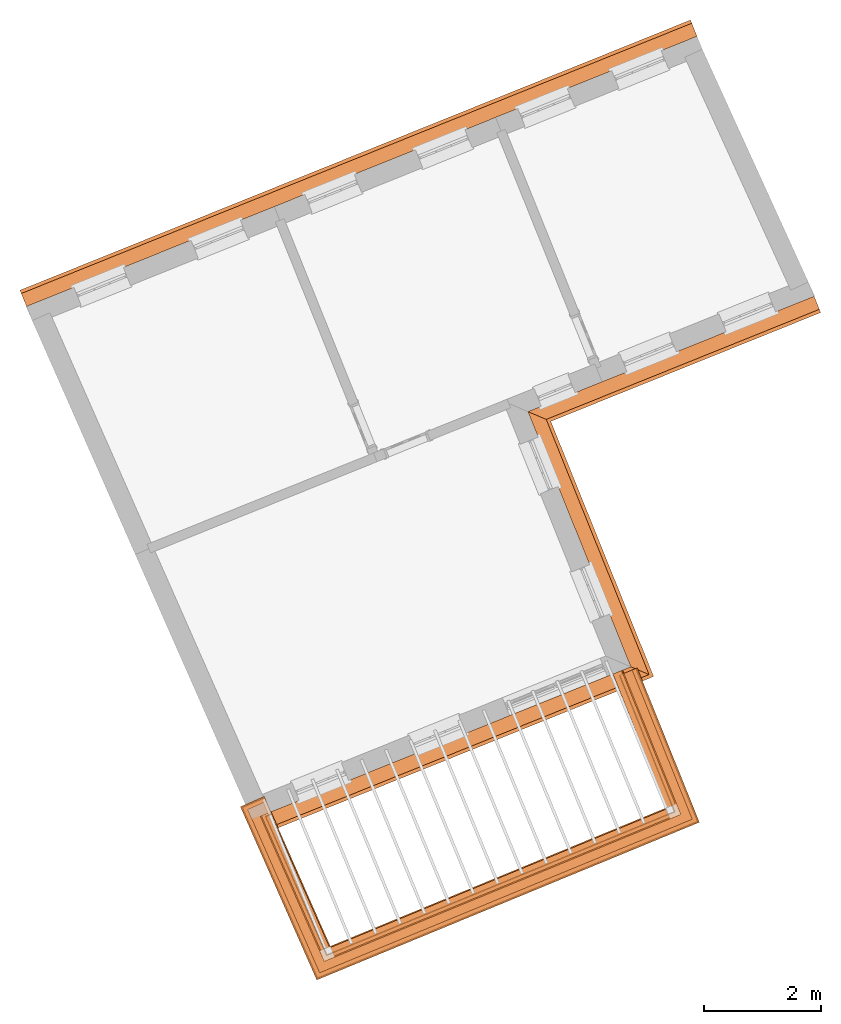
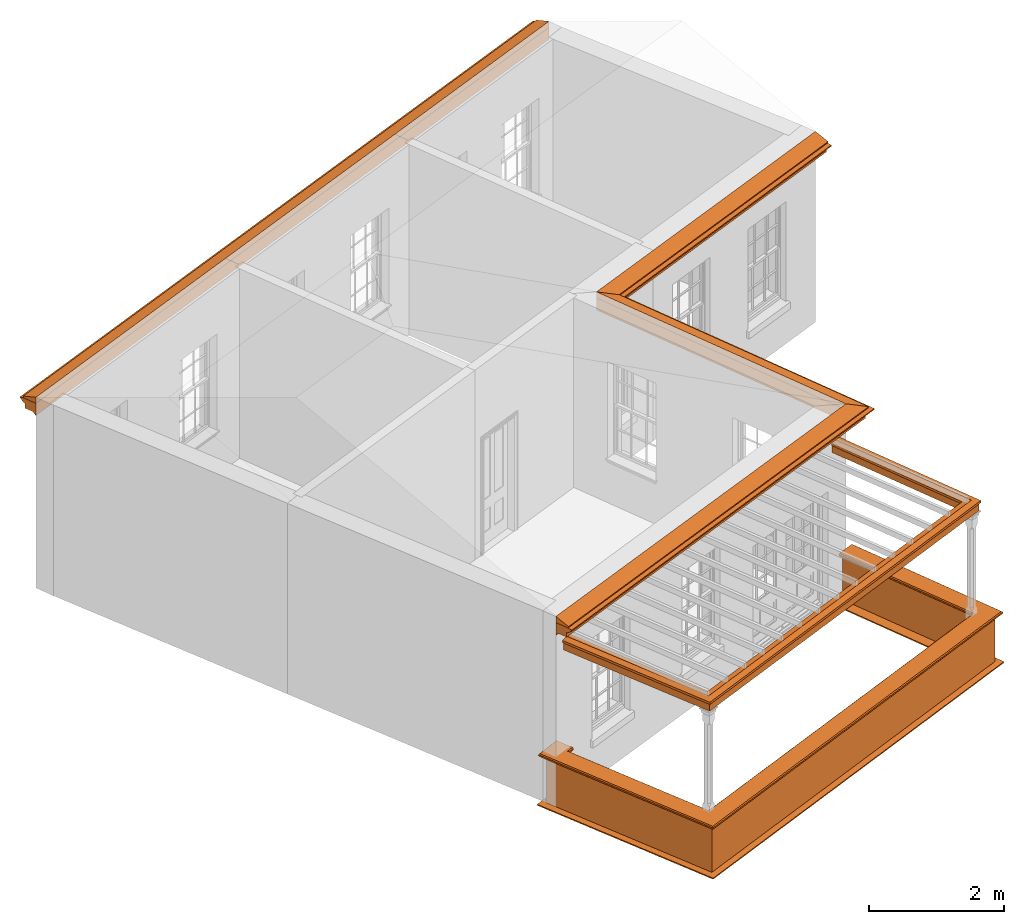
# One storey, part 10 of 11: 9 proxies.
"""IFC2X3 building model written with IfcOpenShell, lengths in metres."""

from ifc_helpers import new_model, entity, si_unit, frame, origin, place, context, subcontext, project, spatial, element, save


model = new_model("IFC2X3")

# Units and contexts
model_context = context("Model", 3, world=origin())
body_context = subcontext(model_context, "Body", "Model", "MODEL_VIEW")
ifc_project = project(units=[si_unit("PLANEANGLEUNIT", "RADIAN"), si_unit("MASSUNIT", "GRAM", prefix="KILO"), si_unit("FORCEUNIT", "NEWTON", prefix="KILO"), si_unit("LENGTHUNIT", "METRE")], contexts=[model_context])

# Site, building, storey
site_placement = place(None, origin())
site = spatial("IfcSite", under=ifc_project, at=site_placement, CompositionType="ELEMENT")
building_placement = place(None, origin())
building = spatial("IfcBuilding", under=site, at=building_placement, Name="Building plot-6", CompositionType="ELEMENT")
storey_placement = place(None, frame((0.0, 0.0, 7.6)))
storey = spatial("IfcBuildingStorey", under=building, at=storey_placement, Name="Floor 1", CompositionType="ELEMENT", Elevation=7.6)

# Proxies
proxy_1_placement = place(storey_placement, frame((0.0, 0.0, 3.45)))
axis2_placement3_d_1 = entity("IfcAxis2Placement3D", entity("IfcCartesianPoint", [0.0, 0.0, 0.0]))
element("IfcBuildingElementProxy", 1, at=proxy_1_placement, inside=storey, Name="eaves", CompositionType="ELEMENT", context=body_context, shape_type="SweptSolid", held_by="IfcProductRepresentation", body=[
    entity("IfcSurfaceCurveSweptAreaSolid", entity("IfcArbitraryClosedProfileDef", "AREA", None, entity("IfcPolyline", [entity("IfcCartesianPoint", [-0.11, 0.25]), entity("IfcCartesianPoint", [-0.33, 0.25]), entity("IfcCartesianPoint", [-0.33, 0.265]), entity("IfcCartesianPoint", [-0.318, 0.268]), entity("IfcCartesianPoint", [-0.309, 0.274]), entity("IfcCartesianPoint", [-0.303, 0.283]), entity("IfcCartesianPoint", [-0.3, 0.295]), entity("IfcCartesianPoint", [-0.285, 0.295]), entity("IfcCartesianPoint", [-0.285, 0.455]), entity("IfcCartesianPoint", [-0.205, 0.455]), entity("IfcCartesianPoint", [-0.205, 0.47]), entity("IfcCartesianPoint", [-0.19, 0.47]), entity("IfcCartesianPoint", [-0.189, 0.483]), entity("IfcCartesianPoint", [-0.186, 0.494]), entity("IfcCartesianPoint", [-0.179, 0.506]), entity("IfcCartesianPoint", [-0.17, 0.514]), entity("IfcCartesianPoint", [-0.16, 0.52]), entity("IfcCartesianPoint", [-0.149, 0.529]), entity("IfcCartesianPoint", [-0.143, 0.539]), entity("IfcCartesianPoint", [-0.14, 0.55]), entity("IfcCartesianPoint", [-0.12, 0.55]), entity("IfcCartesianPoint", [-0.11, 0.48]), entity("IfcCartesianPoint", [-0.11, 0.25])])), axis2_placement3_d_1, entity("IfcPolyline", [entity("IfcCartesianPoint", [74.7865149407705, 68.6935179498722]), entity("IfcCartesianPoint", [63.3420321652464, 64.0810953782074])]), 0.0, 1.0, entity("IfcPlane", axis2_placement3_d_1)),
])
proxy_2_placement = place(storey_placement, frame((0.0, 0.0, 3.45)))
axis2_placement3_d_2 = entity("IfcAxis2Placement3D", entity("IfcCartesianPoint", [0.0, 0.0, 0.0]))
element("IfcBuildingElementProxy", 2, at=proxy_2_placement, inside=storey, Name="eaves", CompositionType="ELEMENT", context=body_context, shape_type="SweptSolid", held_by="IfcProductRepresentation", body=[
    entity("IfcSurfaceCurveSweptAreaSolid", entity("IfcArbitraryClosedProfileDef", "AREA", None, entity("IfcPolyline", [entity("IfcCartesianPoint", [-0.11, 0.25]), entity("IfcCartesianPoint", [-0.11, 0.48]), entity("IfcCartesianPoint", [-0.08, 0.49]), entity("IfcCartesianPoint", [0.0, 0.25]), entity("IfcCartesianPoint", [-0.11, 0.25])])), axis2_placement3_d_2, entity("IfcPolyline", [entity("IfcCartesianPoint", [74.7865149407705, 68.6935179498722]), entity("IfcCartesianPoint", [63.3420321652464, 64.0810953782074])]), 0.0, 1.0, entity("IfcPlane", axis2_placement3_d_2)),
])
proxy_3_placement = place(storey_placement, frame((0.0, 0.0, 3.45)))
axis2_placement3_d_3 = entity("IfcAxis2Placement3D", entity("IfcCartesianPoint", [0.0, 0.0, 0.0]))
element("IfcBuildingElementProxy", 3, at=proxy_3_placement, inside=storey, Name="eaves", CompositionType="ELEMENT", context=body_context, shape_type="SweptSolid", held_by="IfcProductRepresentation", body=[
    entity("IfcSurfaceCurveSweptAreaSolid", entity("IfcArbitraryClosedProfileDef", "AREA", None, entity("IfcPolyline", [entity("IfcCartesianPoint", [-0.11, 0.25]), entity("IfcCartesianPoint", [-0.33, 0.25]), entity("IfcCartesianPoint", [-0.33, 0.265]), entity("IfcCartesianPoint", [-0.318, 0.268]), entity("IfcCartesianPoint", [-0.309, 0.274]), entity("IfcCartesianPoint", [-0.303, 0.283]), entity("IfcCartesianPoint", [-0.3, 0.295]), entity("IfcCartesianPoint", [-0.285, 0.295]), entity("IfcCartesianPoint", [-0.285, 0.455]), entity("IfcCartesianPoint", [-0.205, 0.455]), entity("IfcCartesianPoint", [-0.205, 0.47]), entity("IfcCartesianPoint", [-0.19, 0.47]), entity("IfcCartesianPoint", [-0.189, 0.483]), entity("IfcCartesianPoint", [-0.186, 0.494]), entity("IfcCartesianPoint", [-0.179, 0.506]), entity("IfcCartesianPoint", [-0.17, 0.514]), entity("IfcCartesianPoint", [-0.16, 0.52]), entity("IfcCartesianPoint", [-0.149, 0.529]), entity("IfcCartesianPoint", [-0.143, 0.539]), entity("IfcCartesianPoint", [-0.14, 0.55]), entity("IfcCartesianPoint", [-0.12, 0.55]), entity("IfcCartesianPoint", [-0.11, 0.48]), entity("IfcCartesianPoint", [-0.11, 0.25])])), axis2_placement3_d_3, entity("IfcPolyline", [entity("IfcCartesianPoint", [66.9965663179188, 55.7879023583899]), entity("IfcCartesianPoint", [73.2362810537103, 58.3026687879978]), entity("IfcCartesianPoint", [71.4812524972832, 62.6572988706734]), entity("IfcCartesianPoint", [76.5970938384282, 64.7191152530982])]), 0.0, 1.0, entity("IfcPlane", axis2_placement3_d_3)),
])
proxy_4_placement = place(storey_placement, frame((0.0, 0.0, 3.45)))
axis2_placement3_d_4 = entity("IfcAxis2Placement3D", entity("IfcCartesianPoint", [0.0, 0.0, 0.0]))
element("IfcBuildingElementProxy", 4, at=proxy_4_placement, inside=storey, Name="eaves", CompositionType="ELEMENT", context=body_context, shape_type="SweptSolid", held_by="IfcProductRepresentation", body=[
    entity("IfcSurfaceCurveSweptAreaSolid", entity("IfcArbitraryClosedProfileDef", "AREA", None, entity("IfcPolyline", [entity("IfcCartesianPoint", [-0.11, 0.25]), entity("IfcCartesianPoint", [-0.11, 0.48]), entity("IfcCartesianPoint", [-0.08, 0.49]), entity("IfcCartesianPoint", [0.0, 0.25]), entity("IfcCartesianPoint", [-0.11, 0.25])])), axis2_placement3_d_4, entity("IfcPolyline", [entity("IfcCartesianPoint", [66.9965663179188, 55.7879023583899]), entity("IfcCartesianPoint", [73.2362810537103, 58.3026687879978]), entity("IfcCartesianPoint", [71.4812524972832, 62.6572988706734]), entity("IfcCartesianPoint", [76.5970938384282, 64.7191152530982])]), 0.0, 1.0, entity("IfcPlane", axis2_placement3_d_4)),
])
proxy_5_placement = place(storey_placement, origin())
axis2_placement3_d_5 = entity("IfcAxis2Placement3D", entity("IfcCartesianPoint", [0.0, 0.0, 0.0]))
element("IfcBuildingElementProxy", 5, at=proxy_5_placement, inside=storey, Name="parapet", CompositionType="ELEMENT", context=body_context, shape_type="SweptSolid", held_by="IfcProductRepresentation", body=[
    entity("IfcSurfaceCurveSweptAreaSolid", entity("IfcArbitraryClosedProfileDef", "AREA", None, entity("IfcPolyline", [entity("IfcCartesianPoint", [0.0, 0.25]), entity("IfcCartesianPoint", [0.795, 0.25]), entity("IfcCartesianPoint", [0.795, 0.09]), entity("IfcCartesianPoint", [0.02, 0.09]), entity("IfcCartesianPoint", [0.02, -0.08]), entity("IfcCartesianPoint", [0.0, -0.08]), entity("IfcCartesianPoint", [0.0, 0.25])])), axis2_placement3_d_5, entity("IfcPolyline", [entity("IfcCartesianPoint", [67.4449591678155, 55.63800163792]), entity("IfcCartesianPoint", [67.3534501693955, 55.5976766678869]), entity("IfcCartesianPoint", [68.3815028895231, 53.2647282573946]), entity("IfcCartesianPoint", [74.2860954362417, 55.6978375021164]), entity("IfcCartesianPoint", [73.3521617874131, 58.0151419969739])]), 0.0, 1.0, entity("IfcPlane", axis2_placement3_d_5)),
])
proxy_6_placement = place(storey_placement, origin())
axis2_placement3_d_6 = entity("IfcAxis2Placement3D", entity("IfcCartesianPoint", [0.0, 0.0, 0.0]))
element("IfcBuildingElementProxy", 6, at=proxy_6_placement, inside=storey, Name="parapet", CompositionType="ELEMENT", context=body_context, shape_type="SweptSolid", held_by="IfcProductRepresentation", body=[
    entity("IfcSurfaceCurveSweptAreaSolid", entity("IfcArbitraryClosedProfileDef", "AREA", None, entity("IfcPolyline", [entity("IfcCartesianPoint", [0.795, 0.265]), entity("IfcCartesianPoint", [0.807, 0.268]), entity("IfcCartesianPoint", [0.816, 0.274]), entity("IfcCartesianPoint", [0.822, 0.283]), entity("IfcCartesianPoint", [0.825, 0.295]), entity("IfcCartesianPoint", [0.84, 0.295]), entity("IfcCartesianPoint", [0.84, 0.305]), entity("IfcCartesianPoint", [0.842, 0.317]), entity("IfcCartesianPoint", [0.849, 0.326]), entity("IfcCartesianPoint", [0.858, 0.333]), entity("IfcCartesianPoint", [0.87, 0.335]), entity("IfcCartesianPoint", [0.882, 0.333]), entity("IfcCartesianPoint", [0.891, 0.326]), entity("IfcCartesianPoint", [0.898, 0.317]), entity("IfcCartesianPoint", [0.9, 0.305]), entity("IfcCartesianPoint", [0.9, 0.035]), entity("IfcCartesianPoint", [0.898, 0.023]), entity("IfcCartesianPoint", [0.891, 0.014]), entity("IfcCartesianPoint", [0.882, 0.007]), entity("IfcCartesianPoint", [0.87, 0.005]), entity("IfcCartesianPoint", [0.858, 0.007]), entity("IfcCartesianPoint", [0.849, 0.014]), entity("IfcCartesianPoint", [0.842, 0.023]), entity("IfcCartesianPoint", [0.84, 0.035]), entity("IfcCartesianPoint", [0.84, 0.045]), entity("IfcCartesianPoint", [0.825, 0.045]), entity("IfcCartesianPoint", [0.822, 0.057]), entity("IfcCartesianPoint", [0.816, 0.066]), entity("IfcCartesianPoint", [0.807, 0.072]), entity("IfcCartesianPoint", [0.795, 0.075]), entity("IfcCartesianPoint", [0.795, 0.265])])), axis2_placement3_d_6, entity("IfcPolyline", [entity("IfcCartesianPoint", [67.4449591678155, 55.63800163792]), entity("IfcCartesianPoint", [67.3534501693955, 55.5976766678869]), entity("IfcCartesianPoint", [68.3815028895231, 53.2647282573946]), entity("IfcCartesianPoint", [74.2860954362417, 55.6978375021164]), entity("IfcCartesianPoint", [73.3521617874131, 58.0151419969739])]), 0.0, 1.0, entity("IfcPlane", axis2_placement3_d_6)),
])
proxy_7_placement = place(storey_placement, origin())
axis2_placement3_d_7 = entity("IfcAxis2Placement3D", entity("IfcCartesianPoint", [0.0, 0.0, 0.0]))
element("IfcBuildingElementProxy", 7, at=proxy_7_placement, inside=storey, Name="parapet", CompositionType="ELEMENT", context=body_context, shape_type="SweptSolid", held_by="IfcProductRepresentation", body=[
    entity("IfcSurfaceCurveSweptAreaSolid", entity("IfcArbitraryClosedProfileDef", "AREA", None, entity("IfcPolyline", [entity("IfcCartesianPoint", [-0.1, 0.25]), entity("IfcCartesianPoint", [-0.1, 0.265]), entity("IfcCartesianPoint", [-0.085, 0.265]), entity("IfcCartesianPoint", [-0.084, 0.278]), entity("IfcCartesianPoint", [-0.081, 0.289]), entity("IfcCartesianPoint", [-0.074, 0.301]), entity("IfcCartesianPoint", [-0.065, 0.309]), entity("IfcCartesianPoint", [-0.055, 0.315]), entity("IfcCartesianPoint", [-0.044, 0.324]), entity("IfcCartesianPoint", [-0.038, 0.334]), entity("IfcCartesianPoint", [-0.035, 0.345]), entity("IfcCartesianPoint", [-0.015, 0.345]), entity("IfcCartesianPoint", [0.0, 0.25]), entity("IfcCartesianPoint", [-0.1, 0.25])])), axis2_placement3_d_7, entity("IfcPolyline", [entity("IfcCartesianPoint", [67.4449591678155, 55.63800163792]), entity("IfcCartesianPoint", [67.3534501693955, 55.5976766678869]), entity("IfcCartesianPoint", [68.3815028895231, 53.2647282573946]), entity("IfcCartesianPoint", [74.2860954362417, 55.6978375021164]), entity("IfcCartesianPoint", [73.3521617874131, 58.0151419969739])]), 0.0, 1.0, entity("IfcPlane", axis2_placement3_d_7)),
])
proxy_8_placement = place(storey_placement, frame((0.0, 0.0, 3.45)))
axis2_placement3_d_8 = entity("IfcAxis2Placement3D", entity("IfcCartesianPoint", [0.0, 0.0, 0.0]))
element("IfcBuildingElementProxy", 8, at=proxy_8_placement, inside=storey, Name="pergola beam", CompositionType="ELEMENT", context=body_context, shape_type="SweptSolid", held_by="IfcProductRepresentation", body=[
    entity("IfcSurfaceCurveSweptAreaSolid", entity("IfcArbitraryClosedProfileDef", "AREA", None, entity("IfcPolyline", [entity("IfcCartesianPoint", [-0.7, -0.08]), entity("IfcCartesianPoint", [-0.7, 0.08]), entity("IfcCartesianPoint", [-0.56, 0.08]), entity("IfcCartesianPoint", [-0.56, -0.08]), entity("IfcCartesianPoint", [-0.7, -0.08])])), axis2_placement3_d_8, entity("IfcPolyline", [entity("IfcCartesianPoint", [67.3292551873756, 55.6525820669389]), entity("IfcCartesianPoint", [68.3815028895231, 53.2647282573946]), entity("IfcCartesianPoint", [74.2860954362417, 55.6978375021164]), entity("IfcCartesianPoint", [73.3297332583093, 58.0707923436237])]), 0.0, 1.0, entity("IfcPlane", axis2_placement3_d_8)),
])
proxy_9_placement = place(storey_placement, frame((0.0, 0.0, 3.45)))
axis2_placement3_d_9 = entity("IfcAxis2Placement3D", entity("IfcCartesianPoint", [0.0, 0.0, 0.0]))
element("IfcBuildingElementProxy", 9, at=proxy_9_placement, inside=storey, Name="pergola beam", CompositionType="ELEMENT", context=body_context, shape_type="SweptSolid", held_by="IfcProductRepresentation", body=[
    entity("IfcSurfaceCurveSweptAreaSolid", entity("IfcArbitraryClosedProfileDef", "AREA", None, entity("IfcPolyline", [entity("IfcCartesianPoint", [-0.5, 0.0]), entity("IfcCartesianPoint", [-0.52, -0.1]), entity("IfcCartesianPoint", [-0.56, -0.1]), entity("IfcCartesianPoint", [-0.56, 0.1]), entity("IfcCartesianPoint", [-0.52, 0.1]), entity("IfcCartesianPoint", [-0.5, 0.0])])), axis2_placement3_d_9, entity("IfcPolyline", [entity("IfcCartesianPoint", [67.3292551873756, 55.6525820669389]), entity("IfcCartesianPoint", [68.3815028895231, 53.2647282573946]), entity("IfcCartesianPoint", [74.2860954362417, 55.6978375021164]), entity("IfcCartesianPoint", [73.3297332583093, 58.0707923436237])]), 0.0, 1.0, entity("IfcPlane", axis2_placement3_d_9)),
])

save(model, "model.ifc")
